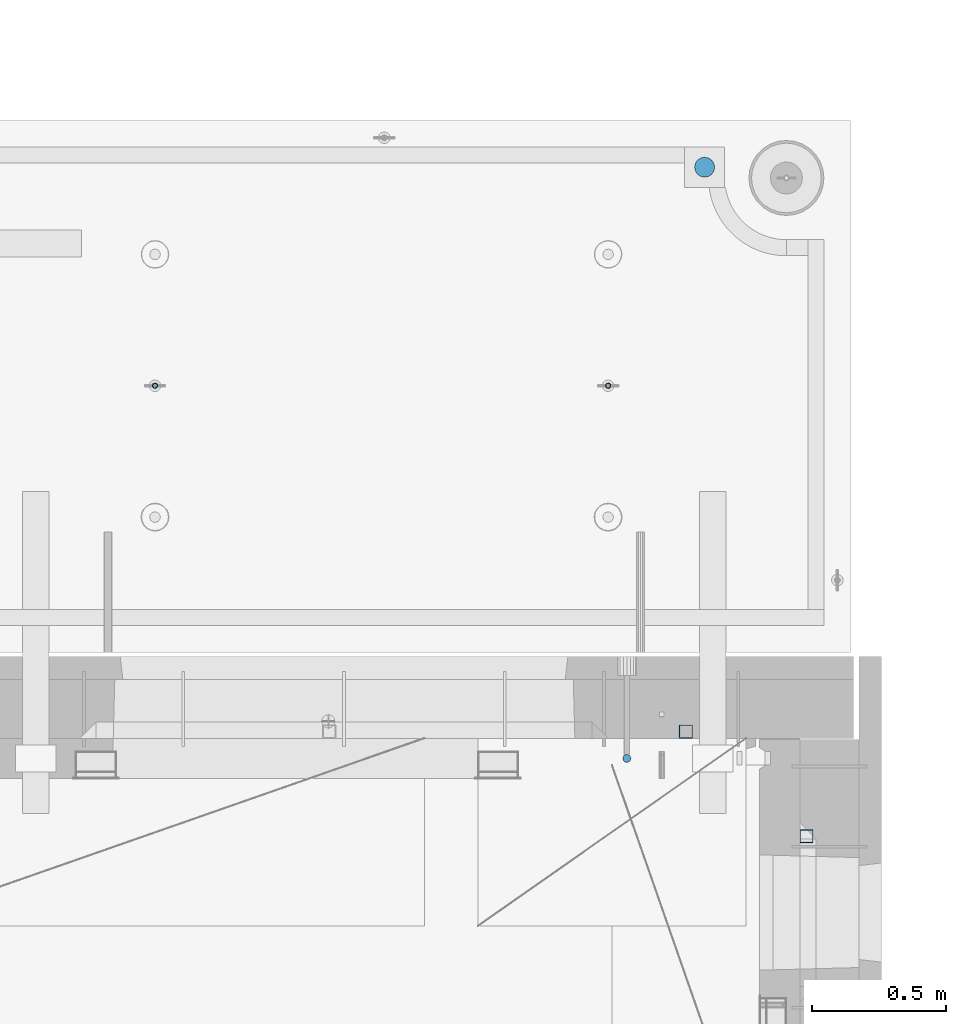
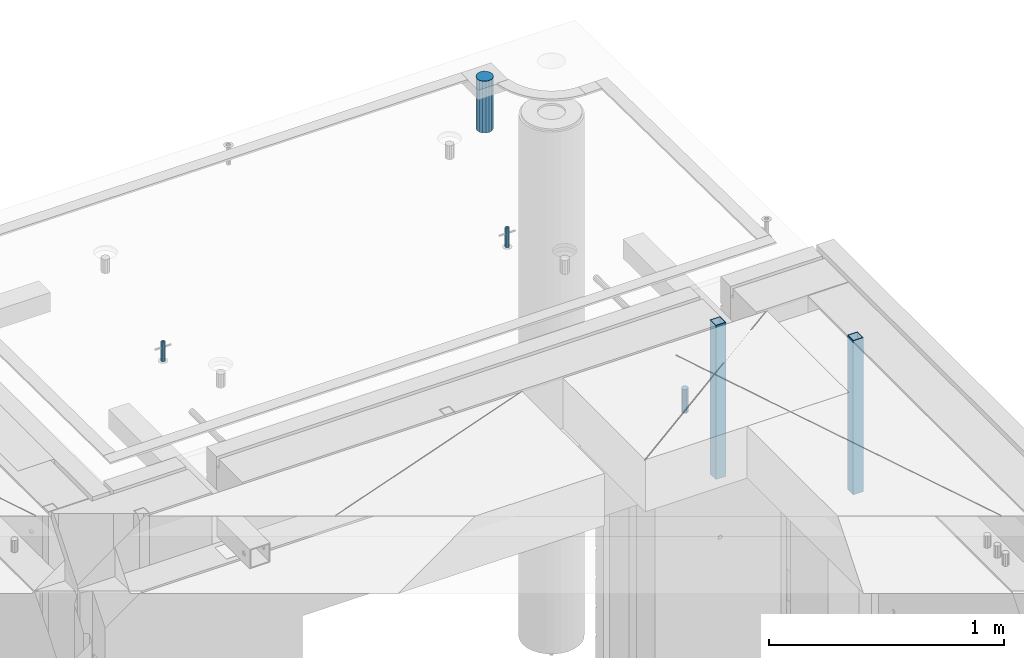
# One storey, part 32 of 325: 6 columns, 7 elements without a shape of their own.
"""IFC2X3 building model written with IfcOpenShell, lengths in millimetres."""

from ifc_helpers import new_model, si_unit, frame, origin_with_axes, place, context, subcontext, project, spatial, faceted_brep, material, type_object, element, aggregate, save


model = new_model("IFC2X3")

# Units and contexts
model_context = context("Model", 3, precision=1e-05, world=origin_with_axes())
body_context = subcontext(model_context, "Body", "Model", "MODEL_VIEW")
ifc_project = project(units=[si_unit("LENGTHUNIT", "METRE", prefix="MILLI"), si_unit("AREAUNIT", "SQUARE_METRE"), si_unit("VOLUMEUNIT", "CUBIC_METRE"), si_unit("MASSUNIT", "GRAM", prefix="KILO"), si_unit("TIMEUNIT", "SECOND"), si_unit("PLANEANGLEUNIT", "RADIAN"), si_unit("SOLIDANGLEUNIT", "STERADIAN"), si_unit("THERMODYNAMICTEMPERATUREUNIT", "DEGREE_CELSIUS"), si_unit("LUMINOUSINTENSITYUNIT", "LUMEN")], contexts=[model_context])

# Site, building, storey
site_placement = place(None, origin_with_axes())
site = spatial("IfcSite", under=ifc_project, at=site_placement, CompositionType="ELEMENT")
building_placement = place(site_placement, origin_with_axes())
building = spatial("IfcBuilding", under=site, at=building_placement, CompositionType="ELEMENT")
storey_placement = place(building_placement, origin_with_axes())
storey = spatial("IfcBuildingStorey", under=building, at=storey_placement, Name="1", CompositionType="ELEMENT", Elevation=0.0)

# Assemblies, columns
assembly_1_placement = place(storey_placement, origin_with_axes())
assembly_1 = element("IfcElementAssembly", 1, at=assembly_1_placement, inside=storey, AssemblyPlace="NOTDEFINED", PredefinedType="REINFORCEMENT_UNIT")
ifc_material_1 = material()
column_type_1 = type_object("IfcColumnType", Name="D30", PredefinedType="NOTDEFINED")
column_1_placement = place(assembly_1_placement, frame((34415.0073334623, 20504.9951872205, 84407.5), z_axis=(0.0, -1.0, 0.0), x_axis=(0.0, 0.0, 1.0)))
column_1 = element("IfcColumn", 2, at=column_1_placement, type_object=column_type_1, material=ifc_material_1, ObjectType="D30", context=body_context, shape_type="Brep", body=[
    faceted_brep([(0.0, -15.0, 0.0), (0.0, -12.9903810567666, -7.5), (125.0, -12.9903810567666, -7.5), (125.0, -15.0, 0.0), (0.0, -7.5, -12.9903810567666), (125.0, -7.5, -12.9903810567666), (0.0, 0.0, -15.0), (125.0, 0.0, -15.0), (0.0, 7.5, -12.9903810567666), (125.0, 7.5, -12.9903810567666), (0.0, 12.9903810567666, -7.5), (125.0, 12.9903810567666, -7.5), (0.0, 15.0, 0.0), (125.0, 15.0, 0.0), (0.0, 12.9903810567666, 7.5), (125.0, 12.9903810567666, 7.5), (0.0, 7.5, 12.9903810567666), (125.0, 7.5, 12.9903810567666), (0.0, 0.0, 15.0), (125.0, 0.0, 15.0), (0.0, -7.5, 12.9903810567666), (125.0, -7.5, 12.9903810567666), (0.0, -12.9903810567666, 7.5), (125.0, -12.9903810567666, 7.5)], [[[0, 1, 2, 3]], [[1, 4, 5, 2]], [[4, 6, 7, 5]], [[6, 8, 9, 7]], [[8, 10, 11, 9]], [[10, 12, 13, 11]], [[12, 14, 15, 13]], [[14, 16, 17, 15]], [[16, 18, 19, 17]], [[18, 20, 21, 19]], [[20, 22, 23, 21]], [[22, 0, 3, 23]], [[5, 7, 9, 11, 13, 15, 17, 19, 21, 23, 3, 2]], [[22, 20, 18, 16, 14, 12, 10, 8, 6, 4, 1, 0]]]),
])
assembly_2_placement = place(assembly_1_placement, origin_with_axes())
assembly_2 = element("IfcElementAssembly", 3, at=assembly_2_placement, Name="Steel Assembly", AssemblyPlace="NOTDEFINED", PredefinedType="RIGID_FRAME")
aggregate(assembly_1, [assembly_2, column_1])
ifc_material_2 = material(Name="STEEL/S355J2")
column_type_2 = type_object("IfcColumnType", Name="50X50X3", PredefinedType="NOTDEFINED")
column_2_placement = place(assembly_2_placement, frame((34635.0, 20605.0, 83940.0), z_axis=(1.0, 0.0, 0.0), x_axis=(0.0, 0.0, 1.0)))
column_2 = element("IfcColumn", 4, at=column_2_placement, type_object=column_type_2, material=ifc_material_2, ObjectType="50X50X3", context=body_context, shape_type="Brep", body=[
    faceted_brep([(0.0, 22.0, -22.0), (0.0, -22.0, -22.0), (800.0, -22.0, -22.0), (800.0, 22.0, -22.0), (0.0, -22.0, 22.0), (800.0, -22.0, 22.0), (0.0, 22.0, 22.0), (800.0, 22.0, 22.0), (0.0, 25.0, -25.0), (0.0, 25.0, 25.0), (800.0, 25.0, 25.0), (800.0, 25.0, -25.0), (0.0, -25.0, 25.0), (800.0, -25.0, 25.0), (0.0, -25.0, -25.0), (800.0, -25.0, -25.0)], [[[0, 1, 2, 3]], [[1, 4, 5, 2]], [[4, 6, 7, 5]], [[6, 0, 3, 7]], [[8, 9, 10, 11]], [[9, 12, 13, 10]], [[12, 14, 15, 13]], [[14, 8, 11, 15]], [[13, 15, 11, 10], [5, 7, 3, 2]], [[14, 12, 9, 8], [6, 4, 1, 0]]]),
])
aggregate(assembly_2, [column_2])

# Assemblies, column
assembly_3_placement = place(storey_placement, origin_with_axes())
assembly_3 = element("IfcElementAssembly", 5, at=assembly_3_placement, inside=storey, AssemblyPlace="NOTDEFINED", PredefinedType="REINFORCEMENT_UNIT")
assembly_4_placement = place(assembly_3_placement, origin_with_axes())
assembly_4 = element("IfcElementAssembly", 6, at=assembly_4_placement, Name="Steel Assembly", AssemblyPlace="NOTDEFINED", PredefinedType="RIGID_FRAME")
aggregate(assembly_3, [assembly_4])
column_3_placement = place(assembly_4_placement, frame((35085.0, 20215.0002861023, 83940.0), z_axis=(0.0, -1.0, 0.0), x_axis=(0.0, 0.0, 1.0)))
column_3 = element("IfcColumn", 7, at=column_3_placement, type_object=column_type_2, material=ifc_material_2, ObjectType="50X50X3", context=body_context, shape_type="Brep", body=[
    faceted_brep([(0.0, 22.0, -22.0), (0.0, -22.0, -22.0), (800.0, -22.0, -22.0), (800.0, 22.0, -22.0), (0.0, -22.0, 22.0), (800.0, -22.0, 22.0), (0.0, 22.0, 22.0), (800.0, 22.0, 22.0), (0.0, 25.0, -25.0), (0.0, 25.0, 25.0), (800.0, 25.0, 25.0), (800.0, 25.0, -25.0), (0.0, -25.0, 25.0), (800.0, -25.0, 25.0), (0.0, -25.0, -25.0), (800.0, -25.0, -25.0)], [[[0, 1, 2, 3]], [[1, 4, 5, 2]], [[4, 6, 7, 5]], [[6, 0, 3, 7]], [[8, 9, 10, 11]], [[9, 12, 13, 10]], [[12, 14, 15, 13]], [[14, 8, 11, 15]], [[13, 15, 11, 10], [5, 7, 3, 2]], [[14, 12, 9, 8], [6, 4, 1, 0]]]),
])
aggregate(assembly_4, [column_3])

# Assemblies, columns
assembly_5_placement = place(storey_placement, origin_with_axes())
assembly_5 = element("IfcElementAssembly", 8, at=assembly_5_placement, inside=storey, AssemblyPlace="NOTDEFINED", PredefinedType="REINFORCEMENT_UNIT")
assembly_6_placement = place(assembly_5_placement, origin_with_axes())
assembly_6 = element("IfcElementAssembly", 9, at=assembly_6_placement, Name="Steel Assembly", AssemblyPlace="NOTDEFINED", PredefinedType="RIGID_FRAME")
ifc_material_3 = material(Name="STEEL/1.4301")
column_type_3 = type_object("IfcColumnType", PredefinedType="NOTDEFINED")
column_4_placement = place(assembly_6_placement, frame((32654.9901431868, 21895.0034426477, 84445.0), z_axis=(0.000321686000089053, -0.999999948259057, 0.0), x_axis=(0.0, 0.0, 1.0)))
column_4 = element("IfcColumn", 10, at=column_4_placement, type_object=column_type_3, material=ifc_material_3, context=body_context, shape_type="Brep", body=[
    faceted_brep([(0.0, -8.0, 0.0), (0.0, -6.92820323027263, 4.0), (100.000000000029, -6.92820323027263, 4.0), (100.000000000029, -7.99999999999636, 0.0), (0.0, -4.0, 6.92820323027627), (100.000000000029, -4.0, 6.92820323027536), (0.0, 0.0, 8.0), (100.000000000029, 3.63797880709171e-12, 8.0), (0.0, 4.0, 6.92820323027627), (100.000000000029, 4.0, 6.92820323027536), (0.0, 6.92820323027263, 4.0), (100.000000000029, 6.92820323027627, 3.99999999999909), (0.0, 8.0, 0.0), (100.000000000029, 8.0, 0.0), (0.0, 6.92820323027263, -4.0), (100.000000000029, 6.92820323027627, -4.00000000000091), (0.0, 4.0, -6.92820323027627), (100.000000000029, 4.00000000000364, -6.92820323027536), (0.0, 0.0, -8.0), (100.000000000029, 3.63797880709171e-12, -8.00000000000091), (0.0, -4.0, -6.92820323027627), (100.000000000029, -3.99999999999636, -6.92820323027627), (0.0, -6.92820323027263, -4.0), (100.000000000029, -6.92820323027263, -4.0), (0.0, -10.4999999999927, -1.45519152283669e-11), (0.0, -9.09326673972828, -5.25000000001455), (100.000000000262, -9.09326673972828, -5.25000000001455), (100.000000000262, -10.4999999999927, -1.45519152283669e-11), (0.0, -5.24999999998545, -9.09326673974283), (100.000000000262, -5.24999999998545, -9.09326673974283), (0.0, 7.27595761418343e-12, -10.5), (100.000000000262, 7.27595761418343e-12, -10.5), (0.0, 5.25000000001455, -9.09326673975738), (100.000000000262, 5.25000000001455, -9.09326673975738), (0.0, 9.09326673975011, -5.25000000001455), (100.000000000262, 9.09326673975011, -5.25000000001455), (0.0, 10.5000000000073, -1.45519152283669e-11), (100.000000000262, 10.5000000000073, -1.45519152283669e-11), (0.0, 9.09326673975011, 5.25), (100.000000000262, 9.09326673975011, 5.25), (0.0, 5.25000000000728, 9.09326673972828), (100.000000000262, 5.25000000000728, 9.09326673972828), (0.0, 1.45519152283669e-11, 10.4999999999854), (100.000000000262, 1.45519152283669e-11, 10.4999999999854), (0.0, -5.24999999999272, 9.09326673972828), (100.000000000262, -5.24999999999272, 9.09326673972828), (0.0, -9.09326673972828, 5.24999999998545), (100.000000000262, -9.09326673972828, 5.24999999998545)], [[[0, 1, 2, 3]], [[1, 4, 5, 2]], [[4, 6, 7, 5]], [[6, 8, 9, 7]], [[8, 10, 11, 9]], [[10, 12, 13, 11]], [[12, 14, 15, 13]], [[14, 16, 17, 15]], [[16, 18, 19, 17]], [[18, 20, 21, 19]], [[20, 22, 23, 21]], [[22, 0, 3, 23]], [[24, 25, 26, 27]], [[25, 28, 29, 26]], [[28, 30, 31, 29]], [[30, 32, 33, 31]], [[32, 34, 35, 33]], [[34, 36, 37, 35]], [[36, 38, 39, 37]], [[38, 40, 41, 39]], [[40, 42, 43, 41]], [[42, 44, 45, 43]], [[44, 46, 47, 45]], [[46, 24, 27, 47]], [[29, 31, 33, 35, 37, 39, 41, 43, 45, 47, 27, 26], [5, 7, 9, 11, 13, 15, 17, 19, 21, 23, 3, 2]], [[46, 44, 42, 40, 38, 36, 34, 32, 30, 28, 25, 24], [22, 20, 18, 16, 14, 12, 10, 8, 6, 4, 1, 0]]]),
])
aggregate(assembly_6, [column_4])
assembly_7_placement = place(assembly_5_placement, origin_with_axes())
assembly_7 = element("IfcElementAssembly", 11, at=assembly_7_placement, Name="Steel Assembly", AssemblyPlace="NOTDEFINED", PredefinedType="RIGID_FRAME")
column_5_placement = place(assembly_7_placement, frame((34345.0001431868, 21895.0034426477, 84445.0), z_axis=(0.000321686000089053, -0.999999948259057, 0.0), x_axis=(0.0, 0.0, 1.0)))
column_5 = element("IfcColumn", 12, at=column_5_placement, type_object=column_type_3, material=ifc_material_3, context=body_context, shape_type="Brep", body=[
    faceted_brep([(0.0, -8.0, 0.0), (0.0, -6.92820323027263, 4.0), (100.000000000029, -6.92820323027263, 4.0), (100.000000000029, -7.99999999999636, 0.0), (0.0, -4.0, 6.92820323027627), (100.000000000029, -4.0, 6.92820323027536), (0.0, 0.0, 8.0), (100.000000000029, 3.63797880709171e-12, 8.0), (0.0, 4.0, 6.92820323027627), (100.000000000029, 4.0, 6.92820323027536), (0.0, 6.92820323027263, 4.0), (100.000000000029, 6.92820323027627, 3.99999999999909), (0.0, 8.0, 0.0), (100.000000000029, 8.0, 0.0), (0.0, 6.92820323027263, -4.0), (100.000000000029, 6.92820323027627, -4.00000000000091), (0.0, 4.0, -6.92820323027627), (100.000000000029, 4.00000000000364, -6.92820323027536), (0.0, 0.0, -8.0), (100.000000000029, 3.63797880709171e-12, -8.00000000000091), (0.0, -4.0, -6.92820323027627), (100.000000000029, -3.99999999999636, -6.92820323027627), (0.0, -6.92820323027263, -4.0), (100.000000000029, -6.92820323027263, -4.0), (0.0, -10.4999999999927, -1.45519152283669e-11), (0.0, -9.09326673972828, -5.25000000001455), (100.000000000262, -9.09326673972828, -5.25000000001455), (100.000000000262, -10.4999999999927, -1.45519152283669e-11), (0.0, -5.24999999998545, -9.09326673974283), (100.000000000262, -5.24999999998545, -9.09326673974283), (0.0, 7.27595761418343e-12, -10.5), (100.000000000262, 7.27595761418343e-12, -10.5), (0.0, 5.25000000001455, -9.09326673975738), (100.000000000262, 5.25000000001455, -9.09326673975738), (0.0, 9.09326673975011, -5.25000000001455), (100.000000000262, 9.09326673975011, -5.25000000001455), (0.0, 10.5000000000073, -1.45519152283669e-11), (100.000000000262, 10.5000000000073, -1.45519152283669e-11), (0.0, 9.09326673975011, 5.25), (100.000000000262, 9.09326673975011, 5.25), (0.0, 5.25000000000728, 9.09326673972828), (100.000000000262, 5.25000000000728, 9.09326673972828), (0.0, 1.45519152283669e-11, 10.4999999999854), (100.000000000262, 1.45519152283669e-11, 10.4999999999854), (0.0, -5.24999999999272, 9.09326673972828), (100.000000000262, -5.24999999999272, 9.09326673972828), (0.0, -9.09326673972828, 5.24999999998545), (100.000000000262, -9.09326673972828, 5.24999999998545)], [[[0, 1, 2, 3]], [[1, 4, 5, 2]], [[4, 6, 7, 5]], [[6, 8, 9, 7]], [[8, 10, 11, 9]], [[10, 12, 13, 11]], [[12, 14, 15, 13]], [[14, 16, 17, 15]], [[16, 18, 19, 17]], [[18, 20, 21, 19]], [[20, 22, 23, 21]], [[22, 0, 3, 23]], [[24, 25, 26, 27]], [[25, 28, 29, 26]], [[28, 30, 31, 29]], [[30, 32, 33, 31]], [[32, 34, 35, 33]], [[34, 36, 37, 35]], [[36, 38, 39, 37]], [[38, 40, 41, 39]], [[40, 42, 43, 41]], [[42, 44, 45, 43]], [[44, 46, 47, 45]], [[46, 24, 27, 47]], [[29, 31, 33, 35, 37, 39, 41, 43, 45, 47, 27, 26], [5, 7, 9, 11, 13, 15, 17, 19, 21, 23, 3, 2]], [[46, 44, 42, 40, 38, 36, 34, 32, 30, 28, 25, 24], [22, 20, 18, 16, 14, 12, 10, 8, 6, 4, 1, 0]]]),
])
aggregate(assembly_7, [column_5])
ifc_material_4 = material()
column_type_4 = type_object("IfcColumnType", Name="D75", PredefinedType="NOTDEFINED")
column_6_placement = place(assembly_5_placement, frame((34704.9998568133, 22710.1651093338, 84440.0), z_axis=(0.9999999949993, 0.000100007000000845, 0.0), x_axis=(0.0, 0.0, 1.0)))
column_6 = element("IfcColumn", 13, at=column_6_placement, type_object=column_type_4, material=ifc_material_4, ObjectType="D75", context=body_context, shape_type="Brep", body=[
    faceted_brep([(0.0, -37.4999999999991, 1.81898940354586e-12), (0.0, -34.6454824691718, -14.3506287136888), (270.0, -34.6454824691718, -14.3506287136888), (270.0, -37.4999999999991, 1.81898940354586e-12), (0.0, -26.5165042944936, -26.5165042944936), (270.0, -26.5165042944936, -26.5165042944936), (0.0, -14.3506287136906, -34.6454824691718), (270.0, -14.3506287136906, -34.6454824691718), (0.0, 9.09494701772928e-13, -37.4999999999982), (270.0, 9.09494701772928e-13, -37.4999999999982), (0.0, 14.3506287136915, -34.6454824691718), (270.0, 14.3506287136915, -34.6454824691718), (0.0, 26.5165042944973, -26.5165042944927), (270.0, 26.5165042944973, -26.5165042944927), (0.0, 34.6454824691746, -14.3506287136897), (270.0, 34.6454824691746, -14.3506287136897), (0.0, 37.5000000000018, 1.81898940354586e-12), (270.0, 37.5000000000018, 1.81898940354586e-12), (0.0, 34.6454824691755, 14.3506287136925), (270.0, 34.6454824691755, 14.3506287136925), (0.0, 26.5165042944964, 26.5165042944973), (270.0, 26.5165042944964, 26.5165042944973), (0.0, 14.3506287136934, 34.6454824691755), (270.0, 14.3506287136934, 34.6454824691755), (0.0, 1.81898940354586e-12, 37.5000000000027), (270.0, 1.81898940354586e-12, 37.5000000000027), (0.0, -14.3506287136897, 34.6454824691746), (270.0, -14.3506287136897, 34.6454824691746), (0.0, -26.5165042944946, 26.5165042944973), (270.0, -26.5165042944946, 26.5165042944973), (0.0, -34.6454824691718, 14.3506287136925), (270.0, -34.6454824691718, 14.3506287136925)], [[[0, 1, 2, 3]], [[1, 4, 5, 2]], [[4, 6, 7, 5]], [[6, 8, 9, 7]], [[8, 10, 11, 9]], [[10, 12, 13, 11]], [[12, 14, 15, 13]], [[14, 16, 17, 15]], [[16, 18, 19, 17]], [[18, 20, 21, 19]], [[20, 22, 23, 21]], [[22, 24, 25, 23]], [[24, 26, 27, 25]], [[26, 28, 29, 27]], [[28, 30, 31, 29]], [[30, 0, 3, 31]], [[5, 7, 9, 11, 13, 15, 17, 19, 21, 23, 25, 27, 29, 31, 3, 2]], [[30, 28, 26, 24, 22, 20, 18, 16, 14, 12, 10, 8, 6, 4, 1, 0]]]),
])
aggregate(assembly_5, [assembly_6, assembly_7, column_6])

save(model, "model.ifc")
